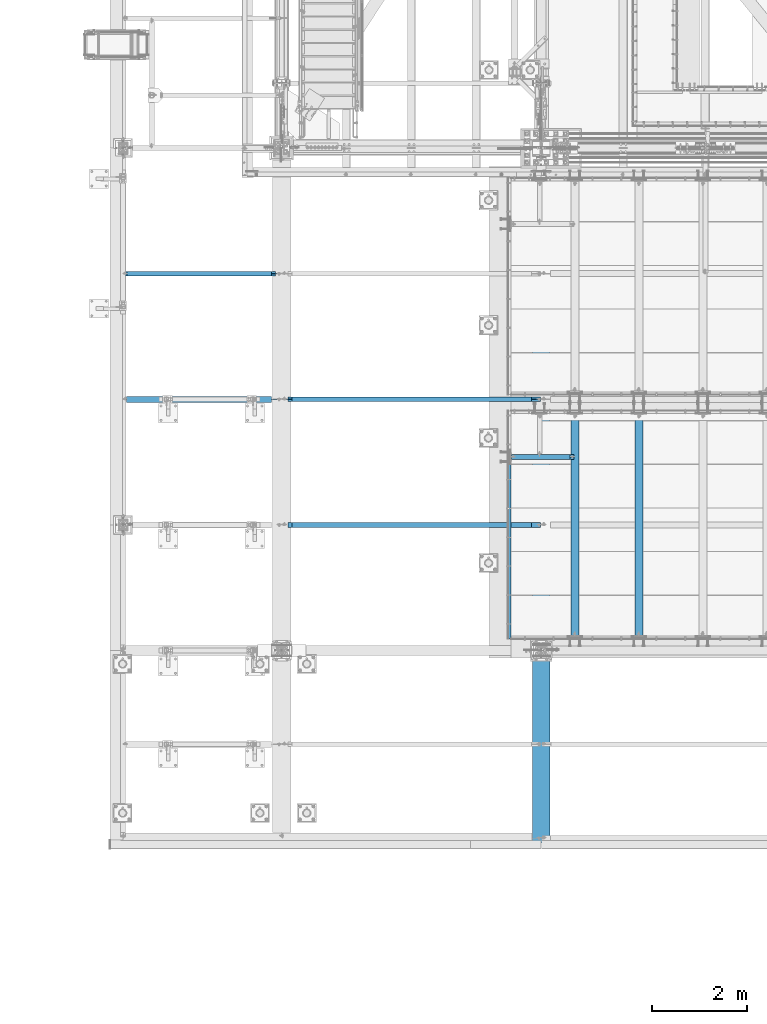
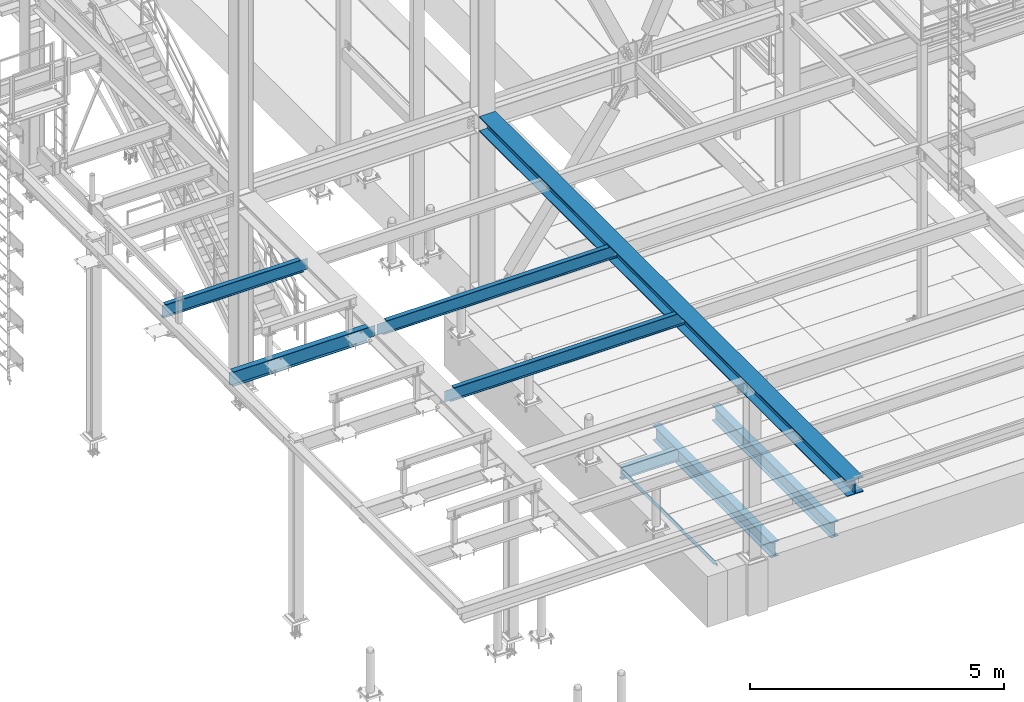
# One storey, part 1739 of 3843: 9 beams, 9 elements without a shape of their own.
"""IFC2X3 building model written with IfcOpenShell, lengths in millimetres."""

from ifc_helpers import new_model, si_unit, frame, origin_with_axes, place, context, subcontext, project, spatial, faceted_brep, material, type_object, element, aggregate, save


model = new_model("IFC2X3")

# Units and contexts
model_context = context("Model", 3, precision=1e-05, world=origin_with_axes())
body_context = subcontext(model_context, "Body", "Model", "MODEL_VIEW")
ifc_project = project(units=[si_unit("LENGTHUNIT", "METRE", prefix="MILLI"), si_unit("AREAUNIT", "SQUARE_METRE"), si_unit("VOLUMEUNIT", "CUBIC_METRE"), si_unit("MASSUNIT", "GRAM", prefix="KILO"), si_unit("TIMEUNIT", "SECOND"), si_unit("PLANEANGLEUNIT", "RADIAN"), si_unit("SOLIDANGLEUNIT", "STERADIAN"), si_unit("THERMODYNAMICTEMPERATUREUNIT", "DEGREE_CELSIUS"), si_unit("LUMINOUSINTENSITYUNIT", "LUMEN")], contexts=[model_context])

# Site, building, storey
site_placement = place(None, origin_with_axes())
site = spatial("IfcSite", under=ifc_project, at=site_placement, CompositionType="ELEMENT")
building_placement = place(site_placement, origin_with_axes())
building = spatial("IfcBuilding", under=site, at=building_placement, Name="Undefined", CompositionType="ELEMENT")
storey_placement = place(building_placement, origin_with_axes())
storey = spatial("IfcBuildingStorey", under=building, at=storey_placement, Name="Undefined", CompositionType="ELEMENT", Elevation=0.0)

# Assembly, beam
assembly_1_placement = place(storey_placement, origin_with_axes())
assembly_1 = element("IfcElementAssembly", 1, at=assembly_1_placement, inside=storey, Name="ANGLE", AssemblyPlace="NOTDEFINED", PredefinedType="RIGID_FRAME")
ifc_material_1 = material(Name="STEEL/A36")
beam_type_1 = type_object("IfcBeamType", Name="L3X3X1/4", PredefinedType="NOTDEFINED")
beam_1_placement = place(assembly_1_placement, frame((41379.775, 15246.35, 30365.7000030518), z_axis=(0.0, 0.0, -1.0), x_axis=(0.0, 1.0, 0.0)))
beam_1 = element("IfcBeam", 2, at=beam_1_placement, type_object=beam_type_1, material=ifc_material_1, Name="ANGLE", ObjectType="L3X3X1/4", context=body_context, shape_type="Brep", body=[
    faceted_brep([(0.0, 38.0999999999985, -38.0999999999985), (0.0, 38.0999999999985, 38.0999999999985), (3679.82485196689, 38.0999999999985, 38.0999999999985), (3679.82485196689, 38.0999999999985, -38.0999999999985), (0.0, 31.75, 38.0999999999985), (3679.82485196689, 31.75, 38.0999999999985), (0.0, 31.75, -31.75), (3679.82485196689, 31.75, -31.75), (0.0, -38.0999999999985, -31.75), (3679.82485196689, -38.0999999999985, -31.75), (0.0, -38.0999999999985, -38.0999999999985), (3679.82485196689, -38.0999999999985, -38.0999999999985)], [[[0, 1, 2, 3]], [[1, 4, 5, 2]], [[4, 6, 7, 5]], [[6, 8, 9, 7]], [[8, 10, 11, 9]], [[10, 0, 3, 11]], [[5, 7, 9, 11, 3, 2]], [[10, 8, 6, 4, 1, 0]]]),
])
aggregate(assembly_1, [beam_1])

assembly_2_placement = place(storey_placement, origin_with_axes())
assembly_2 = element("IfcElementAssembly", 3, at=assembly_2_placement, inside=storey, Name="BEAM", AssemblyPlace="NOTDEFINED", PredefinedType="RIGID_FRAME")
ifc_material_2 = material(Name="STEEL/A992")
beam_type_2 = type_object("IfcBeamType", Name="W12X19", PredefinedType="NOTDEFINED")
beam_2_placement = place(assembly_2_placement, frame((36576.0, 17653.0, 34656.7125), z_axis=(0.0, 0.0, 1.0), x_axis=(1.0, 0.0, 0.0)))
beam_2 = element("IfcBeam", 4, at=beam_2_placement, type_object=beam_type_2, material=ifc_material_2, Name="BEAM", ObjectType="W12X19", context=body_context, shape_type="Brep", body=[
    faceted_brep([(22.2249999999985, -3.47514923012932, -144.462500000001), (22.2249999999985, -3.47492599268662, -153.987500000003), (136.525022932306, -3.4748875878322, -153.987500000003), (136.525022932379, -3.4751108252749, -144.462500000001), (136.525038833555, -50.7999999999993, -144.462500000001), (136.525038833555, -50.7999999999993, -153.987500000003), (5467.35000000001, 50.7999999999993, -144.462500000001), (5467.35000000001, 50.7999999999993, -153.987500000003), (136.52500168042, 50.7999999999993, -153.987500000003), (136.52500168042, 50.7999999999993, -144.462500000001), (136.525017581378, 3.47511084778307, -153.987500000003), (136.525017581444, 3.47488761034037, -144.462500000001), (22.2249999999985, 3.4750724433834, -153.987500000003), (22.2249999999985, 3.4748492059407, -144.462500000001), (22.2249999999985, 3.17499999999927, -144.462500000001), (5467.35000000001, 3.17499999999927, -144.462500000001), (204.88507970878, -3.17499999999927, 110.50422992259), (204.88507970878, 3.17499999999927, 110.50422992259), (200.025000190733, 3.17499999999927, 109.537499999999), (200.025000190733, -3.17499999999927, 109.537499999999), (209.005256176933, -3.17499999999927, 113.257243823064), (209.005256176933, 3.17499999999927, 113.257243823064), (211.758270077407, -3.17499999999927, 117.377420291217), (211.758270077407, 3.17499999999927, 117.377420291217), (212.724999999999, -3.17499999999927, 122.237499809264), (212.724999999999, 3.17499999999927, 122.237499809264), (212.724999999999, -50.7999999999993, 153.987500000003), (212.724999999999, 50.7999999999993, 153.987500000003), (212.724999999999, 50.7999999999993, 144.462500000001), (212.724999999999, 3.17499999999927, 144.462500000001), (212.724999999999, -3.17499999999927, 144.462500000001), (212.724999999999, -50.7999999999993, 144.462500000001), (5283.2, 50.7999999999993, 144.462500000001), (5283.2, 3.17499999999927, 144.462500000001), (5467.35000000001, 3.17499999999927, 103.187500000007), (5467.35000000001, 3.17499999999927, -127.412499999999), (22.2249999999985, 3.17499999999927, -140.112500000003), (22.2249999999985, 3.17499999999927, 90.4875000000029), (22.2249999999985, 3.17499999999927, 109.537499999999), (5283.2, 3.17499999999927, 122.237499809264), (5284.1667299226, 3.17499999999927, 117.377420291217), (5286.91974382307, 3.17499999999927, 113.257243823064), (5291.03992029122, 3.17499999999927, 110.50422992259), (5295.89999980927, 3.17499999999927, 109.537499999999), (5467.35000000001, 3.17499999999927, 109.537499999999), (22.2249999999985, -3.17499999999927, 109.537499999999), (5291.03992029122, -3.17499999999927, 110.50422992259), (5286.91974382307, -3.17499999999927, 113.257243823064), (5284.1667299226, -3.17499999999927, 117.377420291217), (5283.2, -3.17499999999927, 122.237499809264), (5283.2, -3.17499999999927, 144.462500000001), (22.2249999999985, -3.17499999999927, -144.462500000001), (5467.35000000001, -3.17499999999927, -144.462500000001), (5467.35000000001, -3.17499999999927, 109.537499999999), (5295.89999980927, -3.17499999999927, 109.537499999999), (5283.2, -50.7999999999993, 144.462500000001), (5283.2, -50.7999999999993, 153.987500000003), (5283.2, 50.7999999999993, 153.987500000003), (5467.35000000001, -50.7999999999993, -144.462500000001), (5467.35000000001, -50.7999999999993, -153.987500000003)], [[[0, 1, 2, 3]], [[4, 3, 2, 5]], [[6, 7, 8, 9]], [[9, 8, 10, 11]], [[11, 10, 12, 13]], [[14, 15, 6, 9, 11, 13]], [[16, 17, 18, 19]], [[20, 21, 17, 16]], [[22, 23, 21, 20]], [[24, 25, 23, 22]], [[26, 27, 28, 29, 25, 24, 30, 31]], [[29, 28, 32, 33]], [[34, 35, 15, 14, 36, 37, 38, 18, 17, 21, 23, 25, 29, 33, 39, 40, 41, 42, 43, 44]], [[19, 18, 38, 45]], [[46, 47, 48, 49, 50, 30, 24, 22, 20, 16, 19, 45, 51, 52, 53, 54]], [[31, 30, 50, 55]], [[26, 31, 55, 56]], [[27, 26, 56, 57]], [[28, 27, 57, 32]], [[56, 55, 50, 49, 39, 33, 32, 57]], [[48, 40, 39, 49]], [[47, 41, 40, 48]], [[46, 42, 41, 47]], [[54, 43, 42, 46]], [[53, 44, 43, 54]], [[52, 58, 59, 7, 6, 15, 35, 34, 44, 53]], [[59, 58, 4, 5]], [[1, 12, 10, 8, 7, 59, 5, 2]], [[51, 45, 38, 37, 36, 14, 13, 12, 1, 0]], [[58, 52, 51, 0, 3, 4]]]),
])
aggregate(assembly_2, [beam_2])

assembly_3_placement = place(storey_placement, origin_with_axes())
assembly_3 = element("IfcElementAssembly", 5, at=assembly_3_placement, inside=storey, Name="BEAM", AssemblyPlace="NOTDEFINED", PredefinedType="RIGID_FRAME")
beam_3_placement = place(assembly_3_placement, frame((36576.0, 20307.3, 34656.7125), z_axis=(0.0, 0.0, 1.0), x_axis=(1.0, 0.0, 0.0)))
beam_3 = element("IfcBeam", 6, at=beam_3_placement, type_object=beam_type_2, material=ifc_material_2, Name="BEAM", ObjectType="W12X19", context=body_context, shape_type="Brep", body=[
    faceted_brep([(22.2249999999985, -3.47514923012932, -144.462500000001), (22.2249999999985, -3.47492599268662, -153.987500000003), (136.525022932306, -3.4748875878322, -153.987500000003), (136.525022932379, -3.4751108252749, -144.462500000001), (136.525038833555, -50.7999999999993, -144.462500000001), (136.525038833555, -50.7999999999993, -153.987500000003), (5467.35000000001, 50.7999999999993, -144.462500000001), (5467.35000000001, 50.7999999999993, -153.987500000003), (136.52500168042, 50.7999999999993, -153.987500000003), (136.52500168042, 50.7999999999993, -144.462500000001), (136.525017581378, 3.47511084778307, -153.987500000003), (136.525017581444, 3.47488761034037, -144.462500000001), (22.2249999999985, 3.4750724433834, -153.987500000003), (22.2249999999985, 3.4748492059407, -144.462500000001), (22.2249999999985, 3.17499999999927, -144.462500000001), (5467.35000000001, 3.17499999999927, -144.462500000001), (204.88507970878, -3.17499999999927, 110.50422992259), (204.88507970878, 3.17499999999927, 110.50422992259), (200.025000190733, 3.17499999999927, 109.537499999999), (200.025000190733, -3.17499999999927, 109.537499999999), (209.005256176933, -3.17499999999927, 113.257243823064), (209.005256176933, 3.17499999999927, 113.257243823064), (211.758270077407, -3.17499999999927, 117.377420291217), (211.758270077407, 3.17499999999927, 117.377420291217), (212.724999999999, -3.17499999999927, 122.237499809264), (212.724999999999, 3.17499999999927, 122.237499809264), (212.724999999999, -50.7999999999993, 153.987500000003), (212.724999999999, 50.7999999999993, 153.987500000003), (212.724999999999, 50.7999999999993, 144.462500000001), (212.724999999999, 3.17499999999927, 144.462500000001), (212.724999999999, -3.17499999999927, 144.462500000001), (212.724999999999, -50.7999999999993, 144.462500000001), (5283.2, 50.7999999999993, 144.462500000001), (5283.2, 3.17499999999927, 144.462500000001), (5467.35000000001, 3.17499999999927, 103.187500000007), (5467.35000000001, 3.17499999999927, -127.412499999999), (22.2249999999985, 3.17499999999927, -140.112500000003), (22.2249999999985, 3.17499999999927, 90.4875000000029), (22.2249999999985, 3.17499999999927, 109.537499999999), (5283.2, 3.17499999999927, 122.237499809264), (5284.1667299226, 3.17499999999927, 117.377420291217), (5286.91974382307, 3.17499999999927, 113.257243823064), (5291.03992029122, 3.17499999999927, 110.50422992259), (5295.89999980927, 3.17499999999927, 109.537499999999), (5467.35000000001, 3.17499999999927, 109.537499999999), (22.2249999999985, -3.17499999999927, 109.537499999999), (5291.03992029122, -3.17499999999927, 110.50422992259), (5286.91974382307, -3.17499999999927, 113.257243823064), (5284.1667299226, -3.17499999999927, 117.377420291217), (5283.2, -3.17499999999927, 122.237499809264), (5283.2, -3.17499999999927, 144.462500000001), (22.2249999999985, -3.17499999999927, -144.462500000001), (5467.35000000001, -3.17499999999927, -144.462500000001), (5467.35000000001, -3.17499999999927, 109.537499999999), (5295.89999980927, -3.17499999999927, 109.537499999999), (5283.2, -50.7999999999993, 144.462500000001), (5283.2, -50.7999999999993, 153.987500000003), (5283.2, 50.7999999999993, 153.987500000003), (5467.35000000001, -50.7999999999993, -144.462500000001), (5467.35000000001, -50.7999999999993, -153.987500000003)], [[[0, 1, 2, 3]], [[4, 3, 2, 5]], [[6, 7, 8, 9]], [[9, 8, 10, 11]], [[11, 10, 12, 13]], [[14, 15, 6, 9, 11, 13]], [[16, 17, 18, 19]], [[20, 21, 17, 16]], [[22, 23, 21, 20]], [[24, 25, 23, 22]], [[26, 27, 28, 29, 25, 24, 30, 31]], [[29, 28, 32, 33]], [[34, 35, 15, 14, 36, 37, 38, 18, 17, 21, 23, 25, 29, 33, 39, 40, 41, 42, 43, 44]], [[19, 18, 38, 45]], [[46, 47, 48, 49, 50, 30, 24, 22, 20, 16, 19, 45, 51, 52, 53, 54]], [[31, 30, 50, 55]], [[26, 31, 55, 56]], [[27, 26, 56, 57]], [[28, 27, 57, 32]], [[56, 55, 50, 49, 39, 33, 32, 57]], [[48, 40, 39, 49]], [[47, 41, 40, 48]], [[46, 42, 41, 47]], [[54, 43, 42, 46]], [[53, 44, 43, 54]], [[52, 58, 59, 7, 6, 15, 35, 34, 44, 53]], [[59, 58, 4, 5]], [[1, 12, 10, 8, 7, 59, 5, 2]], [[51, 45, 38, 37, 36, 14, 13, 12, 1, 0]], [[58, 52, 51, 0, 3, 4]]]),
])
aggregate(assembly_3, [beam_3])

assembly_4_placement = place(storey_placement, origin_with_axes())
assembly_4 = element("IfcElementAssembly", 7, at=assembly_4_placement, inside=storey, Name="BEAM", AssemblyPlace="NOTDEFINED", PredefinedType="RIGID_FRAME")
beam_4_placement = place(assembly_4_placement, frame((33223.2, 22961.6, 34656.7125), z_axis=(0.0, 0.0, 1.0), x_axis=(1.0, 0.0, 0.0)))
beam_4 = element("IfcBeam", 8, at=beam_4_placement, type_object=beam_type_2, material=ifc_material_2, Name="BEAM", ObjectType="W12X19", context=body_context, shape_type="Brep", body=[
    faceted_brep([(3216.27496437368, 3.47518196220335, -144.462500000001), (3216.27496437389, 3.47481665941814, -153.987500000003), (3216.27493839236, 50.7999999999993, -153.987500000003), (3216.27493839236, 50.7999999999993, -144.462500000001), (3330.575, 3.47524471298311, -144.462500000001), (3330.575, 3.47487941016516, -153.987500000003), (79.3749999999927, 3.17500000000291, 144.462500000001), (79.3749999999927, 50.8000000000029, 144.462500000001), (3140.075, 50.7999999999993, 144.462500000001), (3140.075, 3.17499999999927, 144.462500000001), (79.375, -50.7999999999993, 153.890423164572), (79.3749999999927, 50.8000000000029, 153.987500000003), (79.3749999999927, 3.17500000000291, 141.287499809267), (79.3749999999927, -3.17500000000291, 141.287499809267), (79.3749999999927, -3.17500000000291, 144.462500000001), (79.3749999999927, -50.8000000000029, 144.462500000001), (78.4082700774052, 3.17500000000291, 136.42742029122), (78.4082700774052, -3.17500000000291, 136.42742029122), (75.6552561769277, 3.17500000000291, 132.307243823067), (75.6552561769277, -3.17500000000291, 132.307243823067), (71.535079708774, 3.17500000000291, 129.554229922593), (71.535079708774, -3.17500000000291, 129.554229922593), (66.6750001907276, 3.17500000000291, 128.587500000001), (66.6750001907276, -3.17500000000291, 128.587500000001), (15.8750000000146, 3.17500000000291, 128.587500001042), (15.8750000000146, -3.17500000000291, 128.587500001042), (15.8750000000146, 3.17500000000291, 115.887500001612), (15.8750000000146, 3.17500000000291, -114.712499998386), (15.8749999999927, 3.17500000000291, -144.462500000001), (15.8749999999927, 50.8000000000029, -144.462500000001), (15.8749999999927, 50.8000000000029, -153.987500000003), (15.8749999999927, -50.8000000000029, -153.987500000003), (15.8749999999927, -50.8000000000029, -144.462500000001), (15.8749999999927, -3.17500000000291, -144.462500000001), (3216.2749972555, -50.7999999999993, -153.987500000003), (3216.2749972555, -50.7999999999993, -144.462500000001), (3216.27497127403, -3.47518185517401, -153.987500000003), (3216.27497127382, -3.4748165523888, -144.462500000001), (3330.575, -3.47475380161268, -144.462500000001), (3330.575, -3.47511910443063, -153.987500000003), (3330.575, -3.17499999999927, -144.462500000001), (3147.91492029122, -3.17499999999927, 110.50422992259), (3143.79474382307, -3.17499999999927, 113.257243823064), (3141.0417299226, -3.17499999999927, 117.377420291217), (3140.075, -3.17499999999927, 122.237499809264), (3140.075, -3.17499999999927, 144.462500000001), (3330.575, -3.17499999999927, 109.537499999999), (3152.77499980927, -3.17499999999927, 109.537499999999), (3140.075, -50.7999999999993, 144.462500000001), (3140.075, -50.7999999999993, 153.981811904174), (3140.075, 50.7999999999993, 153.987500000003), (3140.075, 3.17499999999927, 122.237499809264), (3141.0417299226, 3.17499999999927, 117.377420291217), (3143.79474382307, 3.17499999999927, 113.257243823064), (3147.91492029122, 3.17499999999927, 110.50422992259), (3152.77499980927, 3.17499999999927, 109.537499999999), (3330.575, 3.17499999999927, 109.537499999999), (3330.575, 3.17499999999927, 90.4875000000102), (3330.575, 3.17499999999927, -140.112499999996), (3330.575, 3.17499999999927, -144.462500000001)], [[[0, 1, 2, 3]], [[4, 5, 1, 0]], [[6, 7, 8, 9]], [[10, 11, 7, 6, 12, 13, 14, 15]], [[13, 12, 16, 17]], [[17, 16, 18, 19]], [[19, 18, 20, 21]], [[21, 20, 22, 23]], [[23, 22, 24, 25]], [[26, 27, 28, 29, 30, 31, 32, 33, 25, 24]], [[32, 31, 34, 35]], [[35, 34, 36, 37]], [[38, 37, 36, 39]], [[40, 33, 32, 35, 37, 38]], [[41, 42, 43, 44, 45, 14, 13, 17, 19, 21, 23, 25, 33, 40, 46, 47]], [[15, 14, 45, 48]], [[10, 15, 48, 49]], [[11, 10, 49, 50]], [[7, 11, 50, 8]], [[49, 48, 45, 44, 51, 9, 8, 50]], [[43, 52, 51, 44]], [[42, 53, 52, 43]], [[41, 54, 53, 42]], [[47, 55, 54, 41]], [[46, 56, 55, 47]], [[57, 58, 59, 28, 27, 26, 24, 22, 20, 18, 16, 12, 6, 9, 51, 52, 53, 54, 55, 56]], [[3, 29, 28, 59, 4, 0]], [[30, 29, 3, 2]], [[39, 36, 34, 31, 30, 2, 1, 5]], [[59, 58, 57, 56, 46, 40, 38, 39, 5, 4]]]),
])
aggregate(assembly_4, [beam_4])

assembly_5_placement = place(storey_placement, origin_with_axes())
assembly_5 = element("IfcElementAssembly", 9, at=assembly_5_placement, inside=storey, Name="BEAM", AssemblyPlace="NOTDEFINED", PredefinedType="RIGID_FRAME")
beam_type_3 = type_object("IfcBeamType", Name="W14X22", PredefinedType="NOTDEFINED")
beam_5_placement = place(assembly_5_placement, frame((33223.2, 20307.3, 34636.075), z_axis=(0.0, 0.0, 1.0), x_axis=(1.0, 0.0, 0.0)))
beam_5 = element("IfcBeam", 10, at=beam_5_placement, type_object=beam_type_3, material=ifc_material_2, Name="BEAM", ObjectType="W14X22", context=body_context, shape_type="Brep", body=[
    faceted_brep([(15.875, -3.17499999999927, -149.224999999999), (15.875, 3.17499999999927, -149.224999999999), (63.5000001907392, 3.17499999999927, -149.224999999999), (63.5000001907392, -3.17499999999927, -149.224999999999), (68.3600797087856, 3.17499999999927, -150.19172992259), (68.3600797087856, -3.17499999999927, -150.19172992259), (72.4802561769393, 3.17499999999927, -152.944743823064), (72.4802561769393, -3.17499999999927, -152.944743823064), (75.2332700774132, 3.17499999999927, -157.064920291217), (75.2332700774132, -3.17499999999927, -157.064920291217), (76.2000000000044, -3.17499999999927, -161.924999809264), (76.2000000000044, 3.17499999999927, -161.924999809264), (76.2000000000044, 3.17499999999927, -166.6875), (76.2000000000044, 63.5, -166.6875), (76.2000000000044, 63.5, -174.625), (76.2000000000044, -63.5, -174.527828362974), (76.2000000000044, -63.5, -166.6875), (76.2000000000044, -3.17499999999927, -166.6875), (3141.66250000001, 63.5, 166.6875), (3141.66250000001, 3.17499999999927, 166.6875), (76.2000000000044, 3.17499999999927, 166.6875), (76.2000000000044, 63.5, 166.6875), (63.5000001907392, -3.17499999999927, 149.224999999999), (63.5000001907392, 3.17499999999927, 149.224999999999), (15.875, 3.17499999999927, 149.225000000013), (15.875, -3.17499999999927, 149.225000000013), (68.3600797087856, -3.17499999999927, 150.19172992259), (68.3600797087856, 3.17499999999927, 150.19172992259), (72.4802561769393, -3.17499999999927, 152.944743823064), (72.4802561769393, 3.17499999999927, 152.944743823064), (75.2332700774132, -3.17499999999927, 157.064920291217), (75.2332700774132, 3.17499999999927, 157.064920291217), (76.2000000000044, -3.17499999999927, 161.924999809264), (76.2000000000044, 3.17499999999927, 161.924999809264), (3141.66250000001, -63.5, 174.619359304976), (3141.66250000001, 63.5, 174.625), (76.2000000000044, 63.5, 174.625), (76.2000000000044, -63.5, 174.527828362974), (3141.66250000001, -63.5, 166.6875), (76.2000000000044, -63.5, 166.6875), (3141.66250000001, -3.17499999999927, 166.6875), (76.2000000000044, -3.17499999999927, 166.6875), (3141.66250000001, -3.17499999999927, 142.874999809268), (3141.66250000001, 3.17499999999927, 142.874999809268), (3142.6292299226, -3.17499999999927, 138.014920291222), (3142.6292299226, 3.17499999999927, 138.014920291222), (3145.38224382308, -3.17499999999927, 133.894743823068), (3145.38224382308, 3.17499999999927, 133.894743823068), (3149.50242029123, -3.17499999999927, 131.141729922594), (3149.50242029123, 3.17499999999927, 131.141729922594), (3154.36249980928, -3.17499999999927, 130.175000000003), (3154.36249980928, 3.17499999999927, 130.175000000003), (3330.575, -3.17499999999927, 130.175000000003), (3330.575, 3.17499999999927, 130.175000000003), (3330.575, 3.17499999999927, -119.475000000006), (3330.575, 3.17499999999927, 111.125), (3330.575, -3.17499999999927, -130.174999999996), (3330.575, 3.17499999999927, -130.174999999996), (3154.36249980928, -3.17499999999927, -130.174999999996), (3154.36249980928, 3.17499999999927, -130.174999999996), (3149.50242029123, -3.17499999999927, -131.141729922587), (3149.50242029123, 3.17499999999927, -131.141729922587), (3145.38224382308, -3.17499999999927, -133.894743823061), (3145.38224382308, 3.17499999999927, -133.894743823061), (3142.6292299226, -3.17499999999927, -138.014920291214), (3142.6292299226, 3.17499999999927, -138.014920291214), (3141.66250000001, -3.17499999999927, -142.874999809261), (3141.66250000001, 3.17499999999927, -142.874999809261), (3141.66250000001, -3.17499999999927, -166.6875), (3141.66250000001, -63.5, -166.6875), (3141.66250000001, -63.5, -174.619359304976), (3141.66250000001, 63.5, -174.625), (3141.66250000001, 63.5, -166.6875), (3141.66250000001, 3.17499999999927, -166.6875), (15.875, 3.17499999999927, -94.0750000000044), (15.875, 3.17499999999927, 136.524999999994)], [[[0, 1, 2, 3]], [[3, 2, 4, 5]], [[5, 4, 6, 7]], [[7, 6, 8, 9]], [[10, 11, 12, 13, 14, 15, 16, 17]], [[9, 8, 11, 10]], [[18, 19, 20, 21]], [[22, 23, 24, 25]], [[26, 27, 23, 22]], [[28, 29, 27, 26]], [[30, 31, 29, 28]], [[32, 33, 31, 30]], [[34, 35, 36, 37]], [[38, 34, 37, 39]], [[40, 38, 39, 41]], [[37, 36, 21, 20, 33, 32, 41, 39]], [[35, 18, 21, 36]], [[34, 38, 40, 42, 43, 19, 18, 35]], [[44, 45, 43, 42]], [[46, 47, 45, 44]], [[48, 49, 47, 46]], [[50, 51, 49, 48]], [[52, 53, 51, 50]], [[54, 55, 53, 52, 56, 57]], [[56, 58, 59, 57]], [[60, 61, 59, 58]], [[62, 63, 61, 60]], [[64, 65, 63, 62]], [[66, 67, 65, 64]], [[68, 69, 70, 71, 72, 73, 67, 66]], [[69, 68, 17, 16]], [[70, 69, 16, 15]], [[71, 70, 15, 14]], [[72, 71, 14, 13]], [[73, 72, 13, 12]], [[6, 4, 2, 1, 74, 75, 24, 23, 27, 29, 31, 33, 20, 19, 43, 45, 47, 49, 51, 53, 55, 54, 57, 59, 61, 63, 65, 67, 73, 12, 11, 8]], [[25, 24, 75, 74, 1, 0]], [[68, 66, 64, 62, 60, 58, 56, 52, 50, 48, 46, 44, 42, 40, 41, 32, 30, 28, 26, 22, 25, 0, 3, 5, 7, 9, 10, 17]]]),
])
aggregate(assembly_5, [beam_5])

assembly_6_placement = place(storey_placement, origin_with_axes())
assembly_6 = element("IfcElementAssembly", 11, at=assembly_6_placement, inside=storey, Name="BEAM", AssemblyPlace="NOTDEFINED", PredefinedType="RIGID_FRAME")
beam_type_4 = type_object("IfcBeamType", Name="W12X16", PredefinedType="NOTDEFINED")
beam_6_placement = place(assembly_6_placement, frame((41417.875, 19091.275, 30251.4), z_axis=(0.0, 0.0, 1.0), x_axis=(1.0, 0.0, 0.0)))
beam_6 = element("IfcBeam", 12, at=beam_6_placement, type_object=beam_type_4, material=ifc_material_2, Name="BEAM", ObjectType="W12X16", context=body_context, shape_type="Brep", body=[
    faceted_brep([(1253.33125000001, -50.7999999999993, 152.400000000001), (1253.33125000001, -50.7999999999993, 146.049999999999), (1253.33125000001, -3.17499999999927, 146.049999999999), (1253.33125000001, -3.17499999999927, 139.699999809265), (1253.33125000001, 3.17499999999927, 139.699999809265), (1253.33125000001, 3.17499999999927, 146.049999999999), (1253.33125000001, 50.7999999999993, 146.049999999999), (1253.33125000001, 50.7999999999993, 152.400000000001), (1254.2979799226, -3.17499999999927, 134.839920291219), (1254.2979799226, 3.17499999999927, 134.839920291219), (1257.05099382308, -3.17499999999927, 130.719743823065), (1257.05099382308, 3.17499999999927, 130.719743823065), (1261.17117029123, -3.17499999999927, 127.966729922588), (1261.17117029123, 3.17499999999927, 127.966729922588), (1266.03124980928, -3.17499999999927, 127.0), (1266.03124980928, 3.17499999999927, 127.0), (1335.88125000001, -3.17499999999927, 127.0), (1335.88125000001, 3.17499999999927, 127.0), (12.7000030517593, -50.7999999999993, -152.400000000001), (12.7000030517593, -50.7999999999993, -146.049999999999), (12.7000000064072, -3.17500000016298, -146.049999999763), (12.7000000064072, -3.17499999987194, 146.049999999777), (12.7000030517593, -50.7999999999993, 146.049999999999), (12.7000030517593, -50.7999999999993, 152.400000000001), (12.7000030517593, 50.7999999999993, 152.400000000001), (12.7000030517593, 50.7999999999993, 146.049999999999), (12.7000000064072, 3.17500000014843, 146.04999999977), (12.7000000064072, 3.17499999985739, -146.049999999763), (12.7000030517593, 50.7999999999993, -146.049999999999), (12.7000030517593, 50.7999999999993, -152.400000000001), (1335.88125000001, 3.17499999999927, -146.049999999999), (1335.88125000001, 50.7999999999993, -146.049999999999), (1335.88125000001, 50.7999999999993, -152.400000000001), (1335.88125000001, -50.7999999999993, -152.400000000001), (1335.88125000001, -50.7999999999993, -146.049999999999), (1335.88125000001, -3.17499999999927, -146.049999999999), (1335.88125000001, 3.17499999999927, 114.299999999999), (1335.88125000001, 3.17499999999927, -116.299999999999)], [[[0, 1, 2, 3, 4, 5, 6, 7]], [[8, 9, 4, 3]], [[10, 11, 9, 8]], [[12, 13, 11, 10]], [[14, 15, 13, 12]], [[16, 17, 15, 14]], [[18, 19, 20, 21, 22, 23, 24, 25, 26, 27, 28, 29]], [[28, 27, 30, 31]], [[29, 28, 31, 32]], [[18, 29, 32, 33]], [[19, 18, 33, 34]], [[20, 19, 34, 35]], [[12, 10, 8, 3, 2, 21, 20, 35, 16, 14]], [[22, 21, 2, 1]], [[23, 22, 1, 0]], [[24, 23, 0, 7]], [[25, 24, 7, 6]], [[26, 25, 6, 5]], [[36, 37, 30, 27, 26, 5, 4, 9, 11, 13, 15, 17]], [[35, 34, 33, 32, 31, 30, 37, 36, 17, 16]]]),
])
aggregate(assembly_6, [beam_6])

assembly_7_placement = place(storey_placement, origin_with_axes())
assembly_7 = element("IfcElementAssembly", 13, at=assembly_7_placement, inside=storey, Name="BEAM", AssemblyPlace="NOTDEFINED", PredefinedType="RIGID_FRAME")
beam_type_5 = type_object("IfcBeamType", Name="W14X38", PredefinedType="NOTDEFINED")
beam_7_placement = place(assembly_7_placement, frame((44122.975, 15303.5, 30224.4125), z_axis=(0.0, 0.0, 1.0), x_axis=(0.0, 1.0, 0.0)))
beam_7 = element("IfcBeam", 14, at=beam_7_placement, type_object=beam_type_5, material=ifc_material_2, Name="BEAM", ObjectType="W14X38", context=body_context, shape_type="Brep", body=[
    faceted_brep([(12.7000030517447, 85.7249999999985, -179.387500000001), (12.7000030517447, 85.7249999999985, -166.6875), (4689.47499694823, 85.7249999999985, -166.6875), (4689.47499694823, 85.7249999999985, -179.387500000001), (12.7000030517447, 3.96875, -166.6875), (4689.47499694823, 3.96875, -166.6875), (12.7000030517447, 3.96875, 166.6875), (4689.47499694823, 3.96875, 166.6875), (12.7000030517447, 85.7249999999985, 166.6875), (4689.47499694823, 85.7249999999985, 166.6875), (12.7000030517447, 85.7249999999985, 179.387500000001), (4689.47499694823, 85.7249999999985, 179.387500000001), (12.7000030517447, -85.7249999999985, 179.387500000001), (4689.47499694823, -85.7249999999985, 179.387500000001), (12.7000030517447, -85.7249999999985, 166.6875), (4689.47499694823, -85.7249999999985, 166.6875), (12.7000030517447, -3.96875, 166.6875), (4689.47499694823, -3.96875, 166.6875), (12.7000030517447, -3.96875, -166.6875), (4689.47499694823, -3.96875, -166.6875), (12.7000030517447, -85.7249999999985, -166.6875), (4689.47499694823, -85.7249999999985, -166.6875), (12.7000030517447, -85.7249999999985, -179.387500000001), (4689.47499694823, -85.7249999999985, -179.387500000001)], [[[0, 1, 2, 3]], [[1, 4, 5, 2]], [[4, 6, 7, 5]], [[6, 8, 9, 7]], [[8, 10, 11, 9]], [[10, 12, 13, 11]], [[12, 14, 15, 13]], [[14, 16, 17, 15]], [[16, 18, 19, 17]], [[18, 20, 21, 19]], [[20, 22, 23, 21]], [[22, 0, 3, 23]], [[5, 7, 9, 11, 13, 15, 17, 19, 21, 23, 3, 2]], [[22, 20, 18, 16, 14, 12, 10, 8, 6, 4, 1, 0]]]),
])
aggregate(assembly_7, [beam_7])

assembly_8_placement = place(storey_placement, origin_with_axes())
assembly_8 = element("IfcElementAssembly", 15, at=assembly_8_placement, inside=storey, Name="BEAM", AssemblyPlace="NOTDEFINED", PredefinedType="RIGID_FRAME")
beam_8_placement = place(assembly_8_placement, frame((42770.425, 15303.5, 30224.4125), z_axis=(0.0, 0.0, 1.0), x_axis=(0.0, 1.0, 0.0)))
beam_8 = element("IfcBeam", 16, at=beam_8_placement, type_object=beam_type_5, material=ifc_material_2, Name="BEAM", ObjectType="W14X38", context=body_context, shape_type="Brep", body=[
    faceted_brep([(12.7000030517447, 85.7249999999985, -179.387500000001), (12.7000030517447, 85.7249999999985, -166.6875), (4689.47499694823, 85.7249999999985, -166.6875), (4689.47499694823, 85.7249999999985, -179.387500000001), (12.7000030517447, 3.96875, -166.6875), (4689.47499694823, 3.96875, -166.6875), (12.7000030517447, 3.96875, 166.6875), (4689.47499694823, 3.96875, 166.6875), (12.7000030517447, 85.7249999999985, 166.6875), (4689.47499694823, 85.7249999999985, 166.6875), (12.7000030517447, 85.7249999999985, 179.387500000001), (4689.47499694823, 85.7249999999985, 179.387500000001), (12.7000030517447, -85.7249999999985, 179.387500000001), (4689.47499694823, -85.7249999999985, 179.387500000001), (12.7000030517447, -85.7249999999985, 166.6875), (4689.47499694823, -85.7249999999985, 166.6875), (12.7000030517447, -3.96875, 166.6875), (4689.47499694823, -3.96875, 166.6875), (12.7000030517447, -3.96875, -166.6875), (4689.47499694823, -3.96875, -166.6875), (12.7000030517447, -85.7249999999985, -166.6875), (4689.47499694823, -85.7249999999985, -166.6875), (12.7000030517447, -85.7249999999985, -179.387500000001), (4689.47499694823, -85.7249999999985, -179.387500000001)], [[[0, 1, 2, 3]], [[1, 4, 5, 2]], [[4, 6, 7, 5]], [[6, 8, 9, 7]], [[8, 10, 11, 9]], [[10, 12, 13, 11]], [[12, 14, 15, 13]], [[14, 16, 17, 15]], [[16, 18, 19, 17]], [[18, 20, 21, 19]], [[20, 22, 23, 21]], [[22, 0, 3, 23]], [[5, 7, 9, 11, 13, 15, 17, 19, 21, 23, 3, 2]], [[22, 20, 18, 16, 14, 12, 10, 8, 6, 4, 1, 0]]]),
])
aggregate(assembly_8, [beam_8])

assembly_9_placement = place(storey_placement, origin_with_axes())
assembly_9 = element("IfcElementAssembly", 17, at=assembly_9_placement, inside=storey, Name="BEAM", AssemblyPlace="NOTDEFINED", PredefinedType="RIGID_FRAME")
beam_type_6 = type_object("IfcBeamType", Name="W14X99", PredefinedType="NOTDEFINED")
beam_9_placement = place(assembly_9_placement, frame((42062.4, 10934.7, 34631.3125), z_axis=(0.0, 0.0, 1.0), x_axis=(0.0, 1.0, 0.0)))
beam_9 = element("IfcBeam", 18, at=beam_9_placement, type_object=beam_type_6, material=ifc_material_2, Name="BEAM", ObjectType="W14X99", context=body_context, shape_type="Brep", body=[
    faceted_brep([(0.0, -185.737500000003, -160.337500000001), (0.0, -185.737500000003, -179.387499999997), (14490.7, -185.737500000003, -179.387499999997), (14490.7, -185.737500000003, -160.337500000001), (0.0, -6.34999999999854, -160.337500000001), (14490.7, -6.34999999999854, -160.337500000001), (0.0, -6.34999999999854, 160.337500000001), (14490.7, -6.34999999999854, 160.337500000001), (0.0, -185.737500000003, 160.337500000001), (14490.7, -185.737500000003, 160.337500000001), (0.0, -185.737500000003, 179.387499999997), (14490.7, -185.737500000003, 179.387499999997), (0.0, 185.737500000003, 179.387499999997), (14490.7, 185.737500000003, 179.387499999997), (0.0, 185.737500000003, 160.337500000001), (14490.7, 185.737500000003, 160.337500000001), (0.0, 6.34999999999854, 160.337500000001), (14490.7, 6.34999999999854, 160.337500000001), (0.0, 6.34999999999854, -160.337500000001), (14490.7, 6.34999999999854, -160.337500000001), (0.0, 185.737500000003, -160.337500000001), (14490.7, 185.737500000003, -160.337500000001), (0.0, 185.737500000003, -179.387499999997), (14490.7, 185.737500000003, -179.387499999997)], [[[0, 1, 2, 3]], [[4, 0, 3, 5]], [[6, 4, 5, 7]], [[8, 6, 7, 9]], [[10, 8, 9, 11]], [[12, 10, 11, 13]], [[14, 12, 13, 15]], [[16, 14, 15, 17]], [[18, 16, 17, 19]], [[20, 18, 19, 21]], [[1, 0, 4, 6, 8, 10, 12, 14, 16, 18, 20, 22]], [[1, 22, 23, 2]], [[19, 17, 15, 13, 11, 9, 7, 5, 3, 2, 23, 21]], [[22, 20, 21, 23]]]),
])
aggregate(assembly_9, [beam_9])

save(model, "model.ifc")
